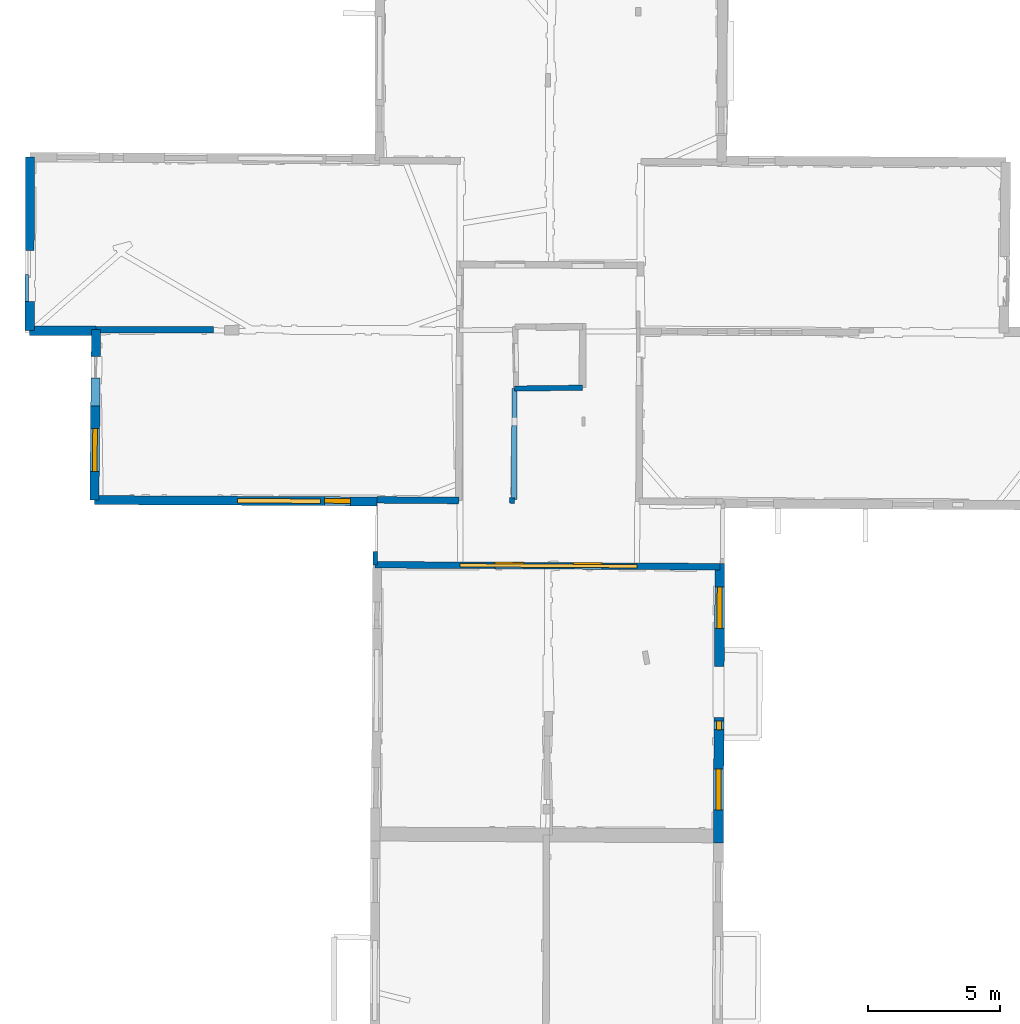
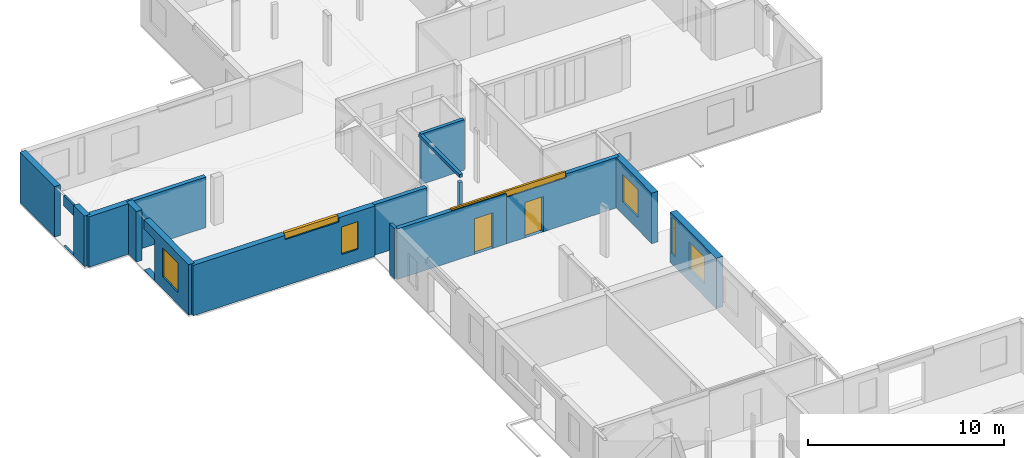
# One storey, part 6 of 14: 17 walls, 8 windows, 2 doors, 12 openings.
"""IFC2X3 building model written with IfcOpenShell, lengths in metres."""

from ifc_helpers import new_model, entity, si_unit, converted_unit, derived_unit, direction, frame, frame_2d, origin, origin_2d_with_axis, place, context, subcontext, project, spatial, polyline, rectangle, outline, extrude, source, transform, mapped, material, layer, layer_set, layer_usage, type_object, type_shapes, element, fill, save


model = new_model("IFC2X3")

# Units and contexts
model_context = context("Model", 3, precision=1e-05, world=origin(), true_north=direction((0.0, 1.0)))
body_context = subcontext(model_context, "Body", "Model", "MODEL_VIEW")
ifc_project = project(units=[si_unit("LENGTHUNIT", "METRE"), si_unit("AREAUNIT", "SQUARE_METRE"), si_unit("VOLUMEUNIT", "CUBIC_METRE"), converted_unit("PLANEANGLEUNIT", "DEGREE", entity("IfcRatioMeasure", 0.0174532925199433), si_unit("PLANEANGLEUNIT", "RADIAN"), dimensions=[0, 0, 0, 0, 0, 0, 0]), si_unit("MASSUNIT", "GRAM", prefix="KILO"), derived_unit("MASSDENSITYUNIT", [(si_unit("MASSUNIT", "GRAM", prefix="KILO"), 1), (si_unit("LENGTHUNIT", "METRE"), -3)]), derived_unit("MOMENTOFINERTIAUNIT", [(si_unit("LENGTHUNIT", "METRE"), 4)]), si_unit("TIMEUNIT", "SECOND"), si_unit("FREQUENCYUNIT", "HERTZ"), si_unit("THERMODYNAMICTEMPERATUREUNIT", "DEGREE_CELSIUS"), derived_unit("THERMALTRANSMITTANCEUNIT", [(si_unit("MASSUNIT", "GRAM", prefix="KILO"), 1), (si_unit("THERMODYNAMICTEMPERATUREUNIT", "KELVIN"), -1), (si_unit("TIMEUNIT", "SECOND"), -3)]), derived_unit("VOLUMETRICFLOWRATEUNIT", [(si_unit("LENGTHUNIT", "METRE"), 3), (si_unit("TIMEUNIT", "SECOND"), -1)]), si_unit("ELECTRICCURRENTUNIT", "AMPERE"), si_unit("ELECTRICVOLTAGEUNIT", "VOLT"), si_unit("POWERUNIT", "WATT"), si_unit("FORCEUNIT", "NEWTON", prefix="KILO"), si_unit("ILLUMINANCEUNIT", "LUX"), si_unit("LUMINOUSFLUXUNIT", "LUMEN"), si_unit("LUMINOUSINTENSITYUNIT", "CANDELA"), derived_unit("USERDEFINED", [(si_unit("MASSUNIT", "GRAM", prefix="KILO"), -1), (si_unit("LENGTHUNIT", "METRE"), -2), (si_unit("TIMEUNIT", "SECOND"), 3), (si_unit("LUMINOUSFLUXUNIT", "LUMEN"), 1)]), derived_unit("LINEARVELOCITYUNIT", [(si_unit("LENGTHUNIT", "METRE"), 1), (si_unit("TIMEUNIT", "SECOND"), -1)]), si_unit("PRESSUREUNIT", "PASCAL"), derived_unit("USERDEFINED", [(si_unit("LENGTHUNIT", "METRE"), -2), (si_unit("MASSUNIT", "GRAM", prefix="KILO"), 1), (si_unit("TIMEUNIT", "SECOND"), -2)]), derived_unit("LINEARFORCEUNIT", [(si_unit("MASSUNIT", "GRAM", prefix="KILO"), 1), (si_unit("LENGTHUNIT", "METRE"), 1), (si_unit("TIMEUNIT", "SECOND"), -2), (si_unit("LENGTHUNIT", "METRE"), -1)]), derived_unit("PLANARFORCEUNIT", [(si_unit("MASSUNIT", "GRAM", prefix="KILO"), 1), (si_unit("LENGTHUNIT", "METRE"), 1), (si_unit("TIMEUNIT", "SECOND"), -2), (si_unit("LENGTHUNIT", "METRE"), -2)])], contexts=[model_context])

# Site, building, storey
placement_1 = place(None, origin())
site = spatial("IfcSite", under=ifc_project, at=placement_1, CompositionType="ELEMENT")
building = spatial("IfcBuilding", under=site, at=placement_1, CompositionType="ELEMENT")
storey_placement = place(placement_1, frame((0.0, 0.0, 8.83152770996094)))
storey = spatial("IfcBuildingStorey", under=building, at=storey_placement, Name="Level 4", CompositionType="ELEMENT", Elevation=8.83152770996094)

# Wall
ifc_material_1 = material(Name="Default wall")
ifc_layer_1 = layer(ifc_material_1, 0.25)
ifc_layer_set_1 = layer_set([ifc_layer_1], Name="wall_thickness_0.2500")
ifc_layer_usage_1 = layer_usage(ifc_layer_set_1, "AXIS2", "POSITIVE", -0.125)
wall_type_1 = type_object("IfcWallType", Name="wall_thickness_0.2500", PredefinedType="STANDARD", material=ifc_layer_set_1)
wall_1_placement = place(storey_placement, frame((-10.799778098172, 57.6936451413503, 0.0), z_axis=(0.0, 0.0, 1.0), x_axis=(0.999997310969071, -0.00231906330820862, 0.0)))
element("IfcWallStandardCase", 1, at=wall_1_placement, inside=storey, type_object=wall_type_1, material=ifc_layer_usage_1, Name="Wall:376", ObjectType="Wall", context=body_context, shape_type="SweptSolid", body=[
    extrude(outline(polyline([(4.43802167289966, -0.125), (4.43802167289966, 0.125), (0.0, 0.125), (0.0, -0.125), (4.43802167289966, -0.125)])), origin(), (0.0, 0.0, 1.0), 3.14668312072754),
])

# Wall, opening, door
wall_2_placement = place(storey_placement, frame((-0.238881779490267, 48.7894002190593, 0.0), z_axis=(0.0, 0.0, 1.0), x_axis=(0.999983802637128, -0.00569161342580891, 0.0)))
wall_2 = element("IfcWallStandardCase", 2, at=wall_2_placement, inside=storey, type_object=wall_type_1, material=ifc_layer_usage_1, Name="Wall:426", ObjectType="Wall", context=body_context, shape_type="SweptSolid", body=[
    extrude(outline(polyline([(6.42081551761286, -0.125), (6.42081551761286, 0.125), (0.0, 0.125), (0.0, -0.125), (6.42081551761286, -0.125)])), origin(), (0.0, 0.0, 1.0), 3.14668312072754),
])
opening_1_placement = place(wall_2_placement, frame((4.53869989328655, -0.125, 0.00547218322753906)))
opening_1 = element("IfcOpeningElement", 3, at=opening_1_placement, cuts=wall_2, Name="Opening : 1100 x 2210 : 332", ObjectType="Opening", context=body_context, shape_type="SweptSolid", body=[
    extrude(rectangle(XDim=1.1, YDim=2.21, at=frame_2d((1.105, 0.55), x_axis=(0.0, 1.0))), frame((0.0, 0.0, 0.0), z_axis=(0.0, 1.0, 0.0), x_axis=(0.0, 0.0, 1.0)), (0.0, 0.0, 1.0), 0.25),
])
ifc_material_2 = material(Name="Door Panel")
door_style_1 = type_object("IfcDoorStyle", Name="Door : 1100 x 2210mm", ConstructionType="NOTDEFINED", OperationType="SINGLE_SWING_RIGHT", ParameterTakesPrecedence=False, Sizeable=False, material=ifc_material_2)
shared_shape_1 = source(origin(), body_context, "Body", "SweptSolid", [
    extrude(rectangle(XDim=0.0625, YDim=1.1, at=origin_2d_with_axis()), frame((0.55, 0.21875, 0.0), z_axis=(0.0, 0.0, 1.0), x_axis=(0.0, 1.0, 0.0)), (0.0, 0.0, 1.0), 2.21),
])
type_shapes(door_style_1, [shared_shape_1])
door_1_placement = place(opening_1_placement, origin())
door_1 = element("IfcDoor", 4, at=door_1_placement, inside=storey, type_object=door_style_1, Name="Door : 1100 x 2210mm : 63", ObjectType="Door : 1100 x 2210mm", OverallHeight=2.21, OverallWidth=1.1, context=body_context, shape_type="MappedRepresentation", body=[
    mapped(shared_shape_1, transform((0.0, 0.0, 0.0), scale=1.0)),
])
fill(opening_1, door_1)

# Wall, openings, door, window
wall_3_placement = place(storey_placement, frame((6.18182973784372, 48.7528554192546, 0.0), z_axis=(0.0, 0.0, 1.0), x_axis=(0.999983799460579, -0.00569217149994799, 0.0)))
wall_3 = element("IfcWallStandardCase", 5, at=wall_3_placement, inside=storey, type_object=wall_type_1, material=ifc_layer_usage_1, Name="Wall:427", ObjectType="Wall", context=body_context, shape_type="SweptSolid", body=[
    extrude(outline(polyline([(6.63463898268571, -0.125), (6.63463898268571, 0.125), (0.0, 0.125), (0.0, -0.125), (6.63463898268571, -0.125)])), origin(), (0.0, 0.0, 1.0), 3.14668312072754),
])
opening_2_placement = place(wall_3_placement, frame((1.09288424222169, -0.125, 0.00547218322753906)))
opening_2 = element("IfcOpeningElement", 6, at=opening_2_placement, cuts=wall_3, Name="Opening : 1090 x 2195 : 333", ObjectType="Opening", context=body_context, shape_type="SweptSolid", body=[
    extrude(rectangle(XDim=1.09, YDim=2.195, at=frame_2d((1.0975, 0.545), x_axis=(0.0, 1.0))), frame((0.0, 0.0, 0.0), z_axis=(0.0, 1.0, 0.0), x_axis=(0.0, 0.0, 1.0)), (0.0, 0.0, 1.0), 0.25),
])
opening_3_placement = place(wall_3_placement, frame((-3.20211556169821, -0.125, 2.90547180175781)))
opening_3 = element("IfcOpeningElement", 7, at=opening_3_placement, cuts=wall_3, Name="Opening : 6705 x 335 : 334", ObjectType="Opening", context=body_context, shape_type="SweptSolid", body=[
    extrude(rectangle(XDim=6.705, YDim=0.335, at=frame_2d((0.1675, 3.3525), x_axis=(0.0, 1.0))), frame((0.0, 0.0, 0.0), z_axis=(0.0, 1.0, 0.0), x_axis=(0.0, 0.0, 1.0)), (0.0, 0.0, 1.0), 0.25),
])
door_style_2 = type_object("IfcDoorStyle", Name="Door : 1090 x 2195mm", ConstructionType="NOTDEFINED", OperationType="SINGLE_SWING_RIGHT", ParameterTakesPrecedence=False, Sizeable=False, material=ifc_material_2)
shared_shape_2 = source(origin(), body_context, "Body", "SweptSolid", [
    extrude(rectangle(XDim=0.0625, YDim=1.09, at=origin_2d_with_axis()), frame((0.545, 0.21875, 0.0), z_axis=(0.0, 0.0, 1.0), x_axis=(0.0, 1.0, 0.0)), (0.0, 0.0, 1.0), 2.195),
])
type_shapes(door_style_2, [shared_shape_2])
door_2_placement = place(opening_2_placement, origin())
door_2 = element("IfcDoor", 8, at=door_2_placement, inside=storey, type_object=door_style_2, Name="Door : 1090 x 2195mm : 64", ObjectType="Door : 1090 x 2195mm", OverallHeight=2.195, OverallWidth=1.09, context=body_context, shape_type="MappedRepresentation", body=[
    mapped(shared_shape_2, transform((0.0, 0.0, 0.0), scale=1.0)),
])
fill(opening_2, door_2)
ifc_material_3 = material(Name="Window Default")
window_style_1 = type_object("IfcWindowStyle", Name="Window : 6705 x 335mm", ConstructionType="NOTDEFINED", OperationType="NOTDEFINED", ParameterTakesPrecedence=False, Sizeable=False, material=ifc_material_3)
shared_shape_3 = source(origin(), body_context, "Body", "SweptSolid", [
    extrude(rectangle(XDim=0.125, YDim=6.705, at=origin_2d_with_axis()), frame((3.3525, 0.125, 0.0), z_axis=(0.0, 0.0, 1.0), x_axis=(0.0, 1.0, 0.0)), (0.0, 0.0, 1.0), 0.335),
])
type_shapes(window_style_1, [shared_shape_3])
window_1_placement = place(opening_3_placement, origin())
window_1 = element("IfcWindow", 9, at=window_1_placement, inside=storey, type_object=window_style_1, Name="Window : 6705 x 335mm : 179", ObjectType="Window : 6705 x 335mm", OverallHeight=0.335, OverallWidth=6.705, context=body_context, shape_type="MappedRepresentation", body=[
    mapped(shared_shape_3, transform((0.0, 0.0, 0.0), scale=1.0)),
])
fill(opening_3, window_1)

# Walls
wall_4_placement = place(storey_placement, frame((-0.171055251693699, 51.2458304217875, 0.0), z_axis=(0.0, 0.0, 1.0), x_axis=(0.999968547958256, -0.00793114709588446, 0.0)))
element("IfcWallStandardCase", 10, at=wall_4_placement, inside=storey, type_object=wall_type_1, material=ifc_layer_usage_1, Name="Wall:450", ObjectType="Wall", context=body_context, shape_type="SweptSolid", body=[
    extrude(outline(polyline([(3.10326191914712, -0.125), (3.10326191914712, 0.125), (0.0, 0.125), (0.0, -0.125), (3.10326191914712, -0.125)])), origin(), (0.0, 0.0, 1.0), 3.14668312072754),
])
ifc_layer_2 = layer(ifc_material_1, 0.349999994039536)
ifc_layer_set_2 = layer_set([ifc_layer_2], Name="wall_thickness_0.3500")
ifc_layer_usage_2 = layer_usage(ifc_layer_set_2, "AXIS2", "POSITIVE", -0.174999997019768)
wall_type_2 = type_object("IfcWallType", Name="wall_thickness_0.3500", PredefinedType="STANDARD", material=ifc_layer_set_2)
wall_5_placement = place(storey_placement, frame((-10.7997782777443, 57.693645580765, 0.0), z_axis=(0.0, 0.0, 1.0), x_axis=(-0.00996155859373599, -0.999950382444241, 0.0)))
element("IfcWallStandardCase", 11, at=wall_5_placement, inside=storey, type_object=wall_type_2, material=ifc_layer_usage_2, Name="Wall:394", ObjectType="Wall", context=body_context, shape_type="SweptSolid", body=[
    extrude(outline(polyline([(1.01939109483121, -0.174999997019768), (1.01939109483121, 0.174999997019768), (0.0, 0.174999997019768), (0.0, -0.174999997019768), (1.01939109483121, -0.174999997019768)])), origin(), (0.0, 0.0, 1.0), 3.14668312072754),
])

# Wall, openings, window
wall_6_placement = place(storey_placement, frame((-10.8180020407484, 55.8642540518943, 0.0), z_axis=(0.0, 0.0, 1.0), x_axis=(-0.00996150965606362, -0.999950382931759, 0.0)))
wall_6 = element("IfcWallStandardCase", 12, at=wall_6_placement, inside=storey, type_object=wall_type_2, material=ifc_layer_usage_2, Name="Wall:395", ObjectType="Wall", context=body_context, shape_type="SweptSolid", body=[
    extrude(outline(polyline([(4.62452373631566, -0.174999997019768), (4.62452373631566, 0.174999997019768), (0.0, 0.174999997019768), (0.0, -0.174999997019768), (4.62452373631566, -0.174999997019768)])), origin(), (0.0, 0.0, 1.0), 3.14668312072754),
])
opening_4_placement = place(wall_6_placement, frame((-0.909613924224386, -0.174999997019768, 0.00547218322753906)))
element("IfcOpeningElement", 13, at=opening_4_placement, cuts=wall_6, Name="Opening : 1980 x 2555 : 319", ObjectType="Opening", context=body_context, shape_type="SweptSolid", body=[
    extrude(rectangle(XDim=1.98, YDim=2.555, at=frame_2d((1.2775, 0.99), x_axis=(0.0, 1.0))), frame((0.0, 0.0, 0.0), z_axis=(0.0, 1.0, 0.0), x_axis=(0.0, 0.0, 1.0)), (0.0, 0.0, 1.0), 0.349999994039536),
])
opening_5_placement = place(wall_6_placement, frame((1.92038336969423, -0.174999997019768, 0.745471954345703)))
opening_5 = element("IfcOpeningElement", 14, at=opening_5_placement, cuts=wall_6, Name="Opening : 1620 x 1815 : 320", ObjectType="Opening", context=body_context, shape_type="SweptSolid", body=[
    extrude(rectangle(XDim=1.62, YDim=1.815, at=frame_2d((0.9075, 0.81), x_axis=(0.0, 1.0))), frame((0.0, 0.0, 0.0), z_axis=(0.0, 1.0, 0.0), x_axis=(0.0, 0.0, 1.0)), (0.0, 0.0, 1.0), 0.349999994039536),
])
window_style_2 = type_object("IfcWindowStyle", Name="Window : 1620 x 1815mm", ConstructionType="NOTDEFINED", OperationType="NOTDEFINED", ParameterTakesPrecedence=False, Sizeable=False, material=ifc_material_3)
shared_shape_4 = source(origin(), body_context, "Body", "SweptSolid", [
    extrude(rectangle(XDim=0.174999997019768, YDim=1.62, at=origin_2d_with_axis()), frame((0.81, 0.174999997019768, 0.0), z_axis=(0.0, 0.0, 1.0), x_axis=(0.0, 1.0, 0.0)), (0.0, 0.0, 1.0), 1.815),
])
type_shapes(window_style_2, [shared_shape_4])
window_2_placement = place(opening_5_placement, origin())
window_2 = element("IfcWindow", 15, at=window_2_placement, inside=storey, type_object=window_style_2, Name="Window : 1620 x 1815mm : 172", ObjectType="Window : 1620 x 1815mm", OverallHeight=1.815, OverallWidth=1.62, context=body_context, shape_type="MappedRepresentation", body=[
    mapped(shared_shape_4, transform((0.0, 0.0, 0.0), scale=1.0)),
])
fill(opening_5, window_2)

# Walls
wall_7_placement = place(storey_placement, frame((-13.3102526395382, 58.7584209562401, 0.0), z_axis=(0.0, 0.0, 1.0), x_axis=(-0.001710527891124, -0.999998537046097, 0.0)))
element("IfcWallStandardCase", 16, at=wall_7_placement, inside=storey, type_object=wall_type_2, material=ifc_layer_usage_2, Name="Wall:432", ObjectType="Wall", context=body_context, shape_type="SweptSolid", body=[
    extrude(outline(polyline([(1.1078164095027, -0.174999997019768), (1.1078164095027, 0.174999997019768), (0.0, 0.174999997019768), (0.0, -0.174999997019768), (1.1078164095027, -0.174999997019768)])), origin(), (0.0, 0.0, 1.0), 3.14668312072754),
])
wall_8_placement = place(storey_placement, frame((-13.3121504046709, 57.6506086122612, 0.0), z_axis=(0.0, 0.0, 1.0), x_axis=(0.99999879084317, -0.00155509234408192, 0.0)))
element("IfcWallStandardCase", 17, at=wall_8_placement, inside=storey, type_object=wall_type_2, material=ifc_layer_usage_2, Name="Wall:465", ObjectType="Wall", context=body_context, shape_type="SweptSolid", body=[
    extrude(outline(polyline([(2.51190870745759, -0.174999997019768), (2.51190870745759, 0.174999997019768), (0.0, 0.174999997019768), (0.0, -0.174999997019768), (2.51190870745759, -0.174999997019768)])), origin(), (0.0, 0.0, 1.0), 3.14668312072754),
])
ifc_layer_3 = layer(ifc_material_1, 0.2)
ifc_layer_set_3 = layer_set([ifc_layer_3], Name="wall_thickness_0.2000")
ifc_layer_usage_3 = layer_usage(ifc_layer_set_3, "AXIS2", "POSITIVE", -0.1)
wall_type_3 = type_object("IfcWallType", Name="wall_thickness_0.2000", PredefinedType="STANDARD", material=ifc_layer_set_3)
wall_9_placement = place(storey_placement, frame((5.04209532305105, 55.4619159537015, 0.0), z_axis=(0.0, 0.0, 1.0), x_axis=(0.999927334745369, 0.0120550914149496, 0.0)))
element("IfcWallStandardCase", 18, at=wall_9_placement, inside=storey, type_object=wall_type_3, material=ifc_layer_usage_3, Name="Wall:451", ObjectType="Wall", context=body_context, shape_type="SweptSolid", body=[
    extrude(outline(polyline([(2.57391225753085, -0.1), (2.57391225753085, 0.1), (0.0, 0.1), (0.0, -0.1), (2.57391225753085, -0.1)])), origin(), (0.0, 0.0, 1.0), 3.14668312072754),
])
wall_10_placement = place(storey_placement, frame((4.95253020413699, 51.3266079993778, 0.0), z_axis=(0.0, 0.0, 1.0), x_axis=(-0.0412875104239751, -0.999147307198989, 0.0)))
element("IfcWallStandardCase", 19, at=wall_10_placement, inside=storey, type_object=wall_type_3, material=ifc_layer_usage_3, Name="Wall:458", ObjectType="Wall", context=body_context, shape_type="SweptSolid", body=[
    extrude(outline(polyline([(0.209998858215793, -0.1), (0.209998858215793, 0.1), (0.0, 0.1), (0.0, -0.1), (0.209998858215793, -0.1)])), origin(), (0.0, 0.0, 1.0), 2.76147270202637),
])

# Wall, openings, windows
ifc_layer_4 = layer(ifc_material_1, 0.379999995231628)
ifc_layer_set_4 = layer_set([ifc_layer_4], Name="wall_thickness_0.3800")
ifc_layer_usage_4 = layer_usage(ifc_layer_set_4, "AXIS2", "POSITIVE", -0.189999997615814)
wall_type_4 = type_object("IfcWallType", Name="wall_thickness_0.3800", PredefinedType="STANDARD", material=ifc_layer_set_4)
wall_11_placement = place(storey_placement, frame((12.7839830959026, 43.0124249813871, 0.0), z_axis=(0.0, 0.0, 1.0), x_axis=(-0.00480128351786472, -0.999988473771864, 0.0)))
wall_11 = element("IfcWallStandardCase", 20, at=wall_11_placement, inside=storey, type_object=wall_type_4, material=ifc_layer_usage_4, Name="Wall:462", ObjectType="Wall", context=body_context, shape_type="SweptSolid", body=[
    extrude(outline(polyline([(4.75140516861197, -0.189999997615814), (4.75140516861197, 0.189999997615814), (0.0, 0.189999997615814), (0.0, -0.189999997615814), (4.75140516861197, -0.189999997615814)])), origin(), (0.0, 0.0, 1.0), 3.14668312072754),
])
opening_6_placement = place(wall_11_placement, frame((0.142450052204209, -0.189999997615814, 2.22147178649902)))
opening_6 = element("IfcOpeningElement", 21, at=opening_6_placement, cuts=wall_11, Name="Opening : 340 x 720 : 356", ObjectType="Opening", context=body_context, shape_type="SweptSolid", body=[
    extrude(rectangle(XDim=0.34, YDim=0.72, at=frame_2d((0.36, 0.17), x_axis=(0.0, 1.0))), frame((0.0, 0.0, 0.0), z_axis=(0.0, 1.0, 0.0), x_axis=(0.0, 0.0, 1.0)), (0.0, 0.0, 1.0), 0.379999995231628),
])
opening_7_placement = place(wall_11_placement, frame((0.142450052204209, -0.189999997615814, 0.661472320556641)))
opening_7 = element("IfcOpeningElement", 22, at=opening_7_placement, cuts=wall_11, Name="Opening : 325 x 1565 : 357", ObjectType="Opening", context=body_context, shape_type="SweptSolid", body=[
    extrude(rectangle(XDim=0.325, YDim=1.565, at=frame_2d((0.7825, 0.1625), x_axis=(0.0, 1.0))), frame((0.0, 0.0, 0.0), z_axis=(0.0, 1.0, 0.0), x_axis=(0.0, 0.0, 1.0)), (0.0, 0.0, 1.0), 0.379999995231628),
])
opening_8_placement = place(wall_11_placement, frame((1.95785488501655, -0.189999997615814, 0.800472259521484)))
opening_8 = element("IfcOpeningElement", 23, at=opening_8_placement, cuts=wall_11, Name="Opening : 1550 x 1685 : 358", ObjectType="Opening", context=body_context, shape_type="SweptSolid", body=[
    extrude(rectangle(XDim=1.55, YDim=1.685, at=frame_2d((0.8425, 0.775), x_axis=(0.0, 1.0))), frame((0.0, 0.0, 0.0), z_axis=(0.0, 1.0, 0.0), x_axis=(0.0, 0.0, 1.0)), (0.0, 0.0, 1.0), 0.379999995231628),
])
window_style_3 = type_object("IfcWindowStyle", Name="Window : 340 x 720mm", ConstructionType="NOTDEFINED", OperationType="NOTDEFINED", ParameterTakesPrecedence=False, Sizeable=False, material=ifc_material_3)
shared_shape_5 = source(origin(), body_context, "Body", "SweptSolid", [
    extrude(rectangle(XDim=0.189999997615814, YDim=0.34, at=origin_2d_with_axis()), frame((0.17, 0.189999997615814, 0.0), z_axis=(0.0, 0.0, 1.0), x_axis=(0.0, 1.0, 0.0)), (0.0, 0.0, 1.0), 0.72),
])
type_shapes(window_style_3, [shared_shape_5])
window_3_placement = place(opening_6_placement, origin())
window_3 = element("IfcWindow", 24, at=window_3_placement, inside=storey, type_object=window_style_3, Name="Window : 340 x 720mm : 192", ObjectType="Window : 340 x 720mm", OverallHeight=0.72, OverallWidth=0.34, context=body_context, shape_type="MappedRepresentation", body=[
    mapped(shared_shape_5, transform((0.0, 0.0, 0.0), scale=1.0)),
])
fill(opening_6, window_3)
window_style_4 = type_object("IfcWindowStyle", Name="Window : 325 x 1565mm", ConstructionType="NOTDEFINED", OperationType="NOTDEFINED", ParameterTakesPrecedence=False, Sizeable=False, material=ifc_material_3)
shared_shape_6 = source(origin(), body_context, "Body", "SweptSolid", [
    extrude(rectangle(XDim=0.189999997615814, YDim=0.325, at=origin_2d_with_axis()), frame((0.1625, 0.189999997615814, 0.0), z_axis=(0.0, 0.0, 1.0), x_axis=(0.0, 1.0, 0.0)), (0.0, 0.0, 1.0), 1.565),
])
type_shapes(window_style_4, [shared_shape_6])
window_4_placement = place(opening_7_placement, origin())
window_4 = element("IfcWindow", 25, at=window_4_placement, inside=storey, type_object=window_style_4, Name="Window : 325 x 1565mm : 193", ObjectType="Window : 325 x 1565mm", OverallHeight=1.565, OverallWidth=0.325, context=body_context, shape_type="MappedRepresentation", body=[
    mapped(shared_shape_6, transform((0.0, 0.0, 0.0), scale=1.0)),
])
fill(opening_7, window_4)
window_style_5 = type_object("IfcWindowStyle", Name="Window : 1550 x 1685mm", ConstructionType="NOTDEFINED", OperationType="NOTDEFINED", ParameterTakesPrecedence=False, Sizeable=False, material=ifc_material_3)
shared_shape_7 = source(origin(), body_context, "Body", "SweptSolid", [
    extrude(rectangle(XDim=0.189999997615814, YDim=1.55, at=origin_2d_with_axis()), frame((0.775, 0.189999997615814, 0.0), z_axis=(0.0, 0.0, 1.0), x_axis=(0.0, 1.0, 0.0)), (0.0, 0.0, 1.0), 1.685),
])
type_shapes(window_style_5, [shared_shape_7])
window_5_placement = place(opening_8_placement, origin())
window_5 = element("IfcWindow", 26, at=window_5_placement, inside=storey, type_object=window_style_5, Name="Window : 1550 x 1685mm : 194", ObjectType="Window : 1550 x 1685mm", OverallHeight=1.685, OverallWidth=1.55, context=body_context, shape_type="MappedRepresentation", body=[
    mapped(shared_shape_7, transform((0.0, 0.0, 0.0), scale=1.0)),
])
fill(opening_8, window_5)

# Wall, opening
ifc_layer_5 = layer(ifc_material_1, 0.129999995231628)
ifc_layer_set_5 = layer_set([ifc_layer_5], Name="wall_thickness_0.1300")
ifc_layer_usage_5 = layer_usage(ifc_layer_set_5, "AXIS2", "POSITIVE", -0.0649999976158142)
wall_type_5 = type_object("IfcWallType", Name="wall_thickness_0.1300", PredefinedType="STANDARD", material=ifc_layer_set_5)
wall_12_placement = place(storey_placement, frame((-13.4167386759813, 59.7736716811267, 0.0), z_axis=(0.0, 0.0, 1.0), x_axis=(-0.00278078372887237, -0.999996133613452, 0.0)))
wall_12 = element("IfcWallStandardCase", 27, at=wall_12_placement, inside=storey, type_object=wall_type_5, material=ifc_layer_usage_5, Name="Wall:385", ObjectType="Wall", context=body_context, shape_type="SweptSolid", body=[
    extrude(outline(polyline([(1.01513682896411, -0.0649999976158142), (1.01513682896411, 0.0649999976158142), (0.0, 0.0649999976158142), (0.0, -0.0649999976158142), (1.01513682896411, -0.0649999976158142)])), origin(), (0.0, 0.0, 1.0), 3.14668312072754),
])
opening_9_placement = place(wall_12_placement, frame((-0.948623485695907, -0.0649999976158142, 0.00547218322753906)))
element("IfcOpeningElement", 28, at=opening_9_placement, cuts=wall_12, Name="Opening : 2055 x 2510 : 306", ObjectType="Opening", context=body_context, shape_type="SweptSolid", body=[
    extrude(rectangle(XDim=2.055, YDim=2.51, at=frame_2d((1.255, 1.0275), x_axis=(0.0, 1.0))), frame((0.0, 0.0, 0.0), z_axis=(0.0, 1.0, 0.0), x_axis=(0.0, 0.0, 1.0)), (0.0, 0.0, 1.0), 0.129999995231628),
])

# Wall
ifc_layer_6 = layer(ifc_material_1, 0.340000003576279)
ifc_layer_set_6 = layer_set([ifc_layer_6], Name="wall_thickness_0.3400")
ifc_layer_usage_6 = layer_usage(ifc_layer_set_6, "AXIS2", "POSITIVE", -0.170000001788139)
wall_type_6 = type_object("IfcWallType", Name="wall_thickness_0.3400", PredefinedType="STANDARD", material=ifc_layer_set_6)
wall_13_placement = place(storey_placement, frame((-13.3058970826886, 64.2229908091577, 0.0), z_axis=(0.0, 0.0, 1.0), x_axis=(-0.0017117693563847, -0.999998534921762, 0.0)))
element("IfcWallStandardCase", 29, at=wall_13_placement, inside=storey, type_object=wall_type_6, material=ifc_layer_usage_6, Name="Wall:431", ObjectType="Wall", context=body_context, shape_type="SweptSolid", body=[
    extrude(outline(polyline([(3.54221862956883, -0.170000001788139), (3.54221862956883, 0.170000001788139), (0.0, 0.170000001788139), (0.0, -0.170000001788139), (3.54221862956883, -0.170000001788139)])), origin(), (0.0, 0.0, 1.0), 3.14668312072754),
])

# Wall, openings, windows
wall_14_placement = place(storey_placement, frame((-10.8640693173313, 51.2399595543734, 0.0), z_axis=(0.0, 0.0, 1.0), x_axis=(0.999988260468125, -0.00484550574598589, 0.0)))
wall_14 = element("IfcWallStandardCase", 30, at=wall_14_placement, inside=storey, type_object=wall_type_6, material=ifc_layer_usage_6, Name="Wall:499", ObjectType="Wall", context=body_context, shape_type="SweptSolid", body=[
    extrude(outline(polyline([(10.6926337471873, -0.170000001788139), (10.6926337471873, 0.170000001788139), (0.0, 0.170000001788139), (0.0, -0.170000001788139), (10.6926337471873, -0.170000001788139)])), origin(), (0.0, 0.0, 1.0), 3.14668312072754),
])
opening_10_placement = place(wall_14_placement, frame((5.40937393634225, -0.170000001788139, 2.87547206878662)))
opening_10 = element("IfcOpeningElement", 31, at=opening_10_placement, cuts=wall_14, Name="Opening : 3145 x 365 : 389", ObjectType="Opening", context=body_context, shape_type="SweptSolid", body=[
    extrude(rectangle(XDim=3.145, YDim=0.365, at=frame_2d((0.1825, 1.5725), x_axis=(0.0, 1.0))), frame((0.0, 0.0, 0.0), z_axis=(0.0, 1.0, 0.0), x_axis=(0.0, 0.0, 1.0)), (0.0, 0.0, 1.0), 0.340000003576279),
])
opening_11_placement = place(wall_14_placement, frame((8.70937472559934, -0.170000001788139, 0.795472145080566)))
opening_11 = element("IfcOpeningElement", 32, at=opening_11_placement, cuts=wall_14, Name="Opening : 990 x 1720 : 390", ObjectType="Opening", context=body_context, shape_type="SweptSolid", body=[
    extrude(rectangle(XDim=0.99, YDim=1.72, at=frame_2d((0.86, 0.495), x_axis=(0.0, 1.0))), frame((0.0, 0.0, 0.0), z_axis=(0.0, 1.0, 0.0), x_axis=(0.0, 0.0, 1.0)), (0.0, 0.0, 1.0), 0.340000003576279),
])
window_style_6 = type_object("IfcWindowStyle", Name="Window : 990 x 1720mm", ConstructionType="NOTDEFINED", OperationType="NOTDEFINED", ParameterTakesPrecedence=False, Sizeable=False, material=ifc_material_3)
shared_shape_8 = source(origin(), body_context, "Body", "SweptSolid", [
    extrude(rectangle(XDim=0.185000002384186, YDim=0.99, at=origin_2d_with_axis()), frame((0.495, 0.185000002384186, 0.0), z_axis=(0.0, 0.0, 1.0), x_axis=(0.0, 1.0, 0.0)), (0.0, 0.0, 1.0), 1.72),
])
type_shapes(window_style_6, [shared_shape_8])
window_6_placement = place(opening_11_placement, origin())
window_6 = element("IfcWindow", 33, at=window_6_placement, inside=storey, type_object=window_style_6, Name="Window : 990 x 1720mm : 213", ObjectType="Window : 990 x 1720mm", OverallHeight=1.72, OverallWidth=0.99, context=body_context, shape_type="MappedRepresentation", body=[
    mapped(shared_shape_8, transform((0.0, 0.0, 0.0), scale=1.0)),
])
fill(opening_11, window_6)
window_style_7 = type_object("IfcWindowStyle", Name="Window : 3145 x 365mm", ConstructionType="NOTDEFINED", OperationType="NOTDEFINED", ParameterTakesPrecedence=False, Sizeable=False, material=ifc_material_3)
shared_shape_9 = source(origin(), body_context, "Body", "SweptSolid", [
    extrude(rectangle(XDim=0.170000001788139, YDim=3.145, at=origin_2d_with_axis()), frame((1.5725, 0.170000001788139, 0.0), z_axis=(0.0, 0.0, 1.0), x_axis=(0.0, 1.0, 0.0)), (0.0, 0.0, 1.0), 0.365),
])
type_shapes(window_style_7, [shared_shape_9])
window_7_placement = place(opening_10_placement, origin())
window_7 = element("IfcWindow", 34, at=window_7_placement, inside=storey, type_object=window_style_7, Name="Window : 3145 x 365mm : 212", ObjectType="Window : 3145 x 365mm", OverallHeight=0.365, OverallWidth=3.145, context=body_context, shape_type="MappedRepresentation", body=[
    mapped(shared_shape_9, transform((0.0, 0.0, 0.0), scale=1.0)),
])
fill(opening_10, window_7)

# Wall, opening, window
ifc_layer_7 = layer(ifc_material_1, 0.370000004768372)
ifc_layer_set_7 = layer_set([ifc_layer_7], Name="wall_thickness_0.3700")
ifc_layer_usage_7 = layer_usage(ifc_layer_set_7, "AXIS2", "POSITIVE", -0.185000002384186)
wall_type_7 = type_object("IfcWallType", Name="wall_thickness_0.3700", PredefinedType="STANDARD", material=ifc_layer_set_7)
wall_15_placement = place(storey_placement, frame((12.8169724210455, 48.8422998154878, 0.0), z_axis=(0.0, 0.0, 1.0), x_axis=(-0.00480183171764267, -0.99998847113962, 0.0)))
wall_15 = element("IfcWallStandardCase", 35, at=wall_15_placement, inside=storey, type_object=wall_type_7, material=ifc_layer_usage_7, Name="Wall:461", ObjectType="Wall", context=body_context, shape_type="SweptSolid", body=[
    extrude(outline(polyline([(3.90797733601921, -0.185000002384186), (3.90797733601921, 0.185000002384186), (0.0, 0.185000002384186), (0.0, -0.185000002384186), (3.90797733601921, -0.185000002384186)])), origin(), (0.0, 0.0, 1.0), 3.14668312072754),
])
opening_12_placement = place(wall_15_placement, frame((0.892813369495648, -0.185000002384186, 0.78547191619873)))
opening_12 = element("IfcOpeningElement", 36, at=opening_12_placement, cuts=wall_15, Name="Opening : 1580 x 1715 : 355", ObjectType="Opening", context=body_context, shape_type="SweptSolid", body=[
    extrude(rectangle(XDim=1.58, YDim=1.715, at=frame_2d((0.8575, 0.79), x_axis=(0.0, 1.0))), frame((0.0, 0.0, 0.0), z_axis=(0.0, 1.0, 0.0), x_axis=(0.0, 0.0, 1.0)), (0.0, 0.0, 1.0), 0.370000004768372),
])
window_style_8 = type_object("IfcWindowStyle", Name="Window : 1580 x 1715mm", ConstructionType="NOTDEFINED", OperationType="NOTDEFINED", ParameterTakesPrecedence=False, Sizeable=False, material=ifc_material_3)
shared_shape_10 = source(origin(), body_context, "Body", "SweptSolid", [
    extrude(rectangle(XDim=0.185000002384186, YDim=1.58, at=origin_2d_with_axis()), frame((0.79, 0.185000002384186, 0.0), z_axis=(0.0, 0.0, 1.0), x_axis=(0.0, 1.0, 0.0)), (0.0, 0.0, 1.0), 1.715),
])
type_shapes(window_style_8, [shared_shape_10])
window_8_placement = place(opening_12_placement, origin())
window_8 = element("IfcWindow", 37, at=window_8_placement, inside=storey, type_object=window_style_8, Name="Window : 1580 x 1715mm : 191", ObjectType="Window : 1580 x 1715mm", OverallHeight=1.715, OverallWidth=1.58, context=body_context, shape_type="MappedRepresentation", body=[
    mapped(shared_shape_10, transform((0.0, 0.0, 0.0), scale=1.0)),
])
fill(opening_12, window_8)

# Walls
ifc_layer_8 = layer(ifc_material_1, 0.200000002980232)
ifc_layer_set_8 = layer_set([ifc_layer_8], Name="wall_thickness_0.2000")
ifc_layer_usage_8 = layer_usage(ifc_layer_set_8, "AXIS2", "POSITIVE", -0.100000001490116)
wall_type_8 = type_object("IfcWallType", Name="wall_thickness_0.2000", PredefinedType="STANDARD", material=ifc_layer_set_8)
placement_2 = place(placement_1, frame((0.0, 0.0, 11.7930002212524)))
wall_16_placement = place(placement_2, frame((5.04209493131497, 55.4619203807158, 0.0), z_axis=(0.0, 0.0, 1.0), x_axis=(-0.00264538266658036, -0.999996500969152, 0.0)))
element("IfcWallStandardCase", 38, at=wall_16_placement, inside=storey, type_object=wall_type_8, material=ifc_layer_usage_8, Name="Wall:381", ObjectType="Wall", context=body_context, shape_type="SweptSolid", body=[
    extrude(outline(polyline([(4.19267595570289, -0.100000001490116), (4.19267595570289, 0.100000001490116), (0.0, 0.100000001490116), (0.0, -0.100000001490116), (4.19267595570289, -0.100000001490116)])), origin(), (0.0, 0.0, 1.0), 0.185210609436036),
])
ifc_layer_9 = layer(ifc_material_1, 0.170000001788139)
ifc_layer_set_9 = layer_set([ifc_layer_9], Name="wall_thickness_0.1700")
ifc_layer_usage_9 = layer_usage(ifc_layer_set_9, "AXIS2", "POSITIVE", -0.0850000008940697)
wall_type_9 = type_object("IfcWallType", Name="wall_thickness_0.1700", PredefinedType="STANDARD", material=ifc_layer_set_9)
wall_17_placement = place(storey_placement, frame((-0.236104882263349, 49.2895060619653, 0.0), z_axis=(0.0, 0.0, 1.0), x_axis=(-0.00555256981800618, -0.999984584365387, 0.0)))
element("IfcWallStandardCase", 39, at=wall_17_placement, inside=storey, type_object=wall_type_9, material=ifc_layer_usage_9, Name="Wall:494", ObjectType="Wall", context=body_context, shape_type="SweptSolid", body=[
    extrude(outline(polyline([(0.500114521106159, -0.0850000008940697), (0.500114521106159, 0.0850000008940697), (0.0, 0.0850000008940697), (0.0, -0.0850000008940697), (0.500114521106159, -0.0850000008940697)])), origin(), (0.0, 0.0, 1.0), 3.14668312072754),
])

save(model, "model.ifc")
